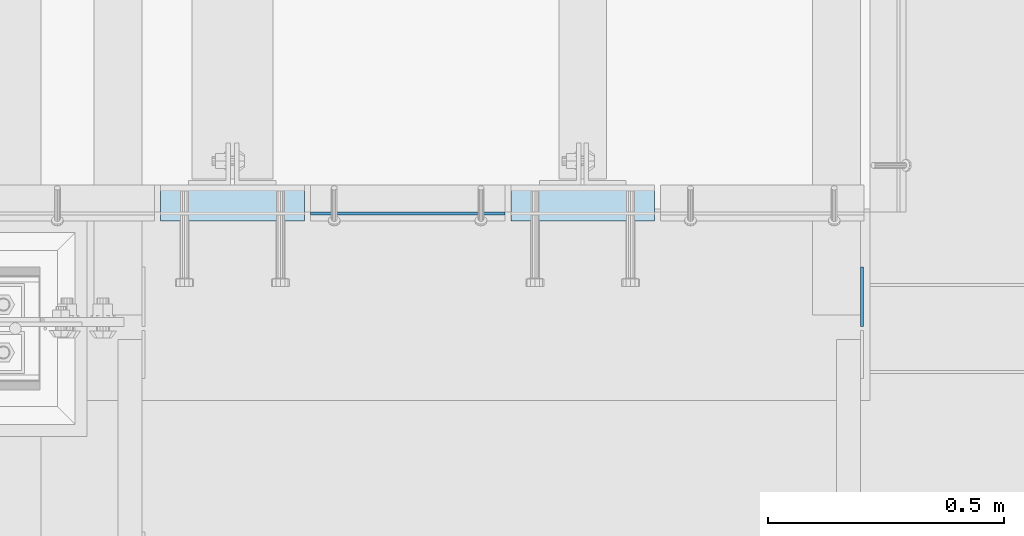
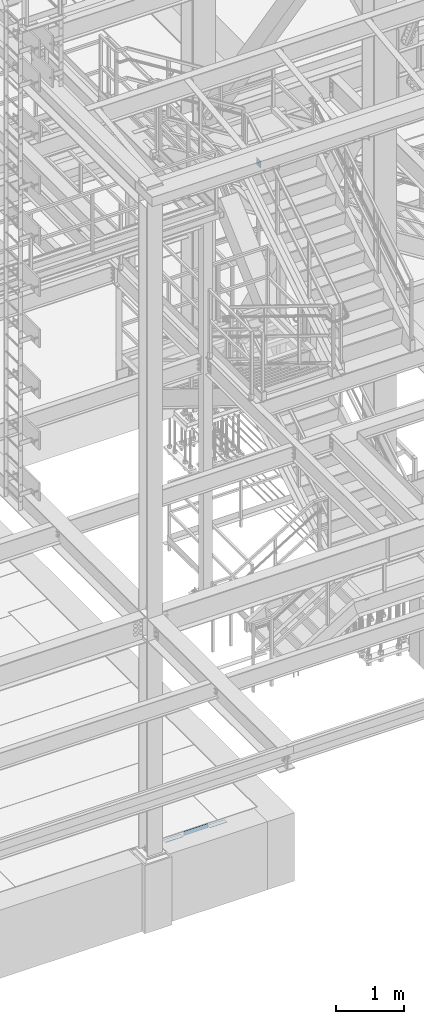
# One storey, part 3050 of 3843: 4 plates, 4 elements without a shape of their own.
"""IFC2X3 building model written with IfcOpenShell, lengths in millimetres."""

from ifc_helpers import new_model, si_unit, frame, origin_with_axes, place, context, subcontext, project, spatial, faceted_brep, material, type_object, element, aggregate, save


model = new_model("IFC2X3")

# Units and contexts
model_context = context("Model", 3, precision=1e-05, world=origin_with_axes())
body_context = subcontext(model_context, "Body", "Model", "MODEL_VIEW")
ifc_project = project(units=[si_unit("LENGTHUNIT", "METRE", prefix="MILLI"), si_unit("AREAUNIT", "SQUARE_METRE"), si_unit("VOLUMEUNIT", "CUBIC_METRE"), si_unit("MASSUNIT", "GRAM", prefix="KILO"), si_unit("TIMEUNIT", "SECOND"), si_unit("PLANEANGLEUNIT", "RADIAN"), si_unit("SOLIDANGLEUNIT", "STERADIAN"), si_unit("THERMODYNAMICTEMPERATUREUNIT", "DEGREE_CELSIUS"), si_unit("LUMINOUSINTENSITYUNIT", "LUMEN")], contexts=[model_context])

# Site, building, storey
site_placement = place(None, origin_with_axes())
site = spatial("IfcSite", under=ifc_project, at=site_placement, CompositionType="ELEMENT")
building_placement = place(site_placement, origin_with_axes())
building = spatial("IfcBuilding", under=site, at=building_placement, Name="Undefined", CompositionType="ELEMENT")
storey_placement = place(building_placement, origin_with_axes())
storey = spatial("IfcBuildingStorey", under=building, at=storey_placement, Name="Undefined", CompositionType="ELEMENT", Elevation=0.0)

# Assembly, plate
assembly_1_placement = place(storey_placement, origin_with_axes())
assembly_1 = element("IfcElementAssembly", 1, at=assembly_1_placement, inside=storey, Name="EMBED PLATE", AssemblyPlace="NOTDEFINED", PredefinedType="RIGID_FRAME")
ifc_material_1 = material(Name="STEEL/A36")
plate_type_1 = type_object("IfcPlateType", PredefinedType="NOTDEFINED")
plate_1_placement = place(assembly_1_placement, frame((49380.775, 15303.5000030518, 30400.625), z_axis=(1.0, 0.0, 0.0), x_axis=(0.0, -1.0, 0.0)))
plate_1 = element("IfcPlate", 2, at=plate_1_placement, type_object=plate_type_1, material=ifc_material_1, Name="PLATE", context=body_context, shape_type="Brep", body=[
    faceted_brep([(0.0, -3.17499999999927, 0.0), (0.0, -3.17499999999927, 304.800000000003), (0.0, 3.17499999999927, 304.800000000003), (0.0, 3.17499999999927, 0.0), (76.1999999999971, -3.17499999999927, 304.799999999996), (76.1999999999971, 3.17499999999927, 304.799999999996), (76.1999999999971, -3.17499999999927, 0.0), (76.1999999999971, 3.17499999999927, 0.0)], [[[0, 1, 2, 3]], [[1, 4, 5, 2]], [[4, 6, 7, 5]], [[6, 0, 3, 7]], [[5, 7, 3, 2]], [[6, 4, 1, 0]]]),
])
aggregate(assembly_1, [plate_1])

assembly_2_placement = place(storey_placement, origin_with_axes())
assembly_2 = element("IfcElementAssembly", 3, at=assembly_2_placement, inside=storey, Name="EMBED PLATE", AssemblyPlace="NOTDEFINED", PredefinedType="RIGID_FRAME")
plate_2_placement = place(assembly_2_placement, frame((50123.725, 15303.5000030518, 30400.625), z_axis=(1.0, 0.0, 0.0), x_axis=(0.0, -1.0, 0.0)))
plate_2 = element("IfcPlate", 4, at=plate_2_placement, type_object=plate_type_1, material=ifc_material_1, Name="PLATE", context=body_context, shape_type="Brep", body=[
    faceted_brep([(0.0, -3.17499999999927, 0.0), (0.0, -3.17499999999927, 304.800000000003), (0.0, 3.17499999999927, 304.800000000003), (0.0, 3.17499999999927, 0.0), (76.1999999999971, -3.17499999999927, 304.799999999996), (76.1999999999971, 3.17499999999927, 304.799999999996), (76.1999999999971, -3.17499999999927, 0.0), (76.1999999999971, 3.17499999999927, 0.0)], [[[0, 1, 2, 3]], [[1, 4, 5, 2]], [[4, 6, 7, 5]], [[6, 0, 3, 7]], [[5, 7, 3, 2]], [[6, 4, 1, 0]]]),
])
aggregate(assembly_2, [plate_2])

assembly_3_placement = place(storey_placement, origin_with_axes())
assembly_3 = element("IfcElementAssembly", 5, at=assembly_3_placement, inside=storey, Name="ANGLE", AssemblyPlace="NOTDEFINED", PredefinedType="RIGID_FRAME")
plate_3_placement = place(assembly_3_placement, frame((49698.2749529241, 15243.1750120328, 30403.8000030518), z_axis=(0.99999999999915, 1.30400000489317e-06, 0.0), x_axis=(0.0, 0.0, 1.0)))
plate_3 = element("IfcPlate", 6, at=plate_3_placement, type_object=plate_type_1, material=ifc_material_1, Name="PLATE", context=body_context, shape_type="Brep", body=[
    faceted_brep([(0.0, -3.17499999999927, 0.0), (-1.00761426438112e-05, -3.17499999982101, 412.750012208846), (-1.00761426438112e-05, 3.17500000018481, 412.750012208831), (0.0, 3.17499999999927, 0.0), (76.1999892724925, -3.17499999981919, 412.750012209093), (76.1999892724925, 3.17500000018481, 412.750012209079), (76.1999999999971, -3.17499999999927, 0.0), (76.1999999999971, 3.17499999999927, 0.0)], [[[0, 1, 2, 3]], [[1, 4, 5, 2]], [[4, 6, 7, 5]], [[6, 0, 3, 7]], [[5, 7, 3, 2]], [[6, 4, 1, 0]]]),
])
aggregate(assembly_3, [plate_3])

assembly_4_placement = place(storey_placement, origin_with_axes())
assembly_4 = element("IfcElementAssembly", 7, at=assembly_4_placement, inside=storey, Name="BEAM", AssemblyPlace="NOTDEFINED", PredefinedType="RIGID_FRAME")
ifc_material_2 = material(Name="STEEL/A572-50")
plate_type_2 = type_object("IfcPlateType", PredefinedType="NOTDEFINED")
plate_4_placement = place(assembly_4_placement, frame((50868.2625, 15002.66875, 42202.1), z_axis=(0.0, 0.0, -1.0), x_axis=(0.0, 1.0, 0.0)))
plate_4 = element("IfcPlate", 8, at=plate_4_placement, type_object=plate_type_2, material=ifc_material_2, Name="PLATE", context=body_context, shape_type="Brep", body=[
    faceted_brep([(0.0, -3.17499999999927, 0.0), (0.0, -3.17500000000291, 107.950000000004), (0.0, 3.17500000000291, 107.950000000004), (0.0, 3.17499999999927, 0.0), (19.0500000000029, -3.17500000000291, 127.0), (19.0500000000029, 3.17500000000291, 127.0), (127.0, -3.17500000000291, 127.0), (127.0, 3.17500000000291, 127.0), (127.0, -3.17500000000291, 0.0), (127.0, 3.17500000000291, 0.0)], [[[0, 1, 2, 3]], [[1, 4, 5, 2]], [[4, 6, 7, 5]], [[6, 8, 9, 7]], [[8, 0, 3, 9]], [[5, 7, 9, 3, 2]], [[8, 6, 4, 1, 0]]]),
])
aggregate(assembly_4, [plate_4])

save(model, "model.ifc")
